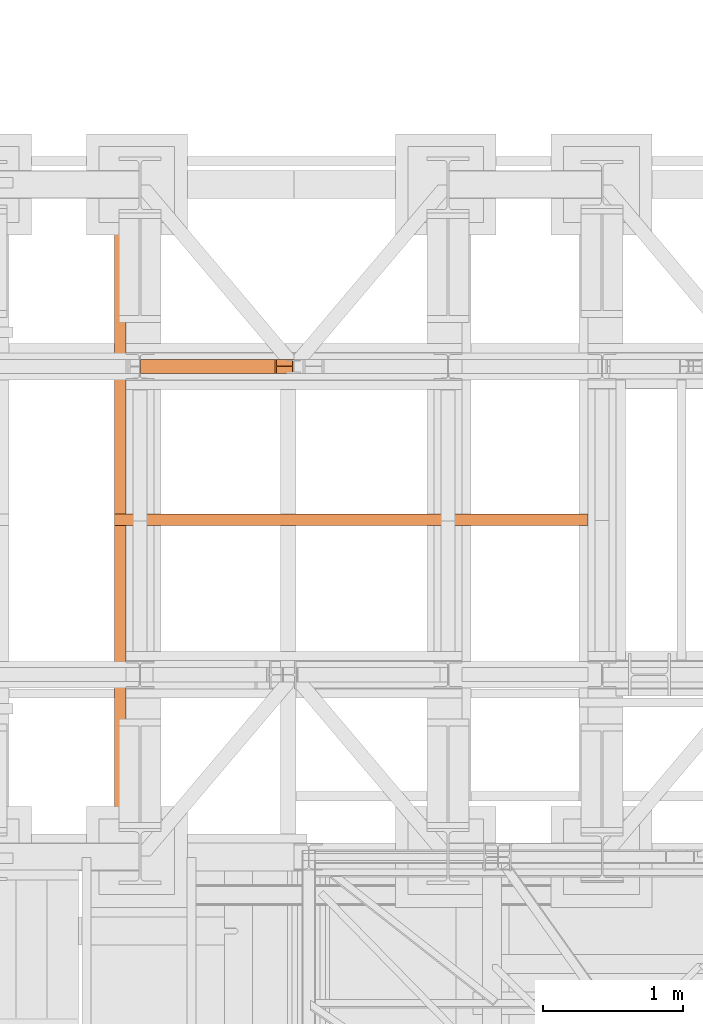
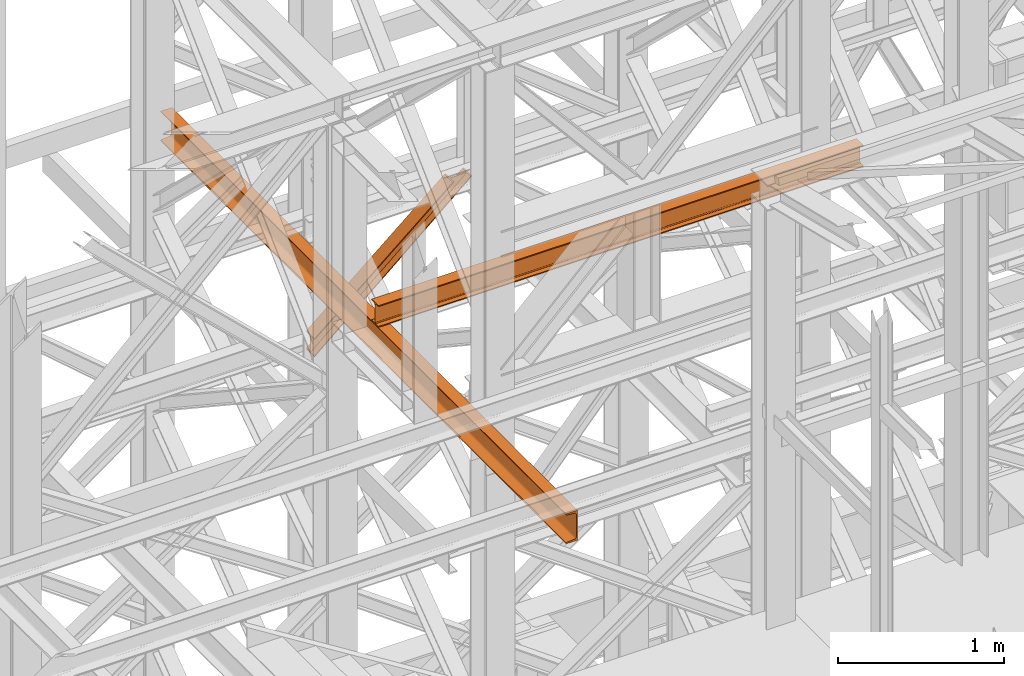
# One storey, part 117 of 208: 3 proxies.
"""IFC2X3 building model written with IfcOpenShell, lengths in millimetres."""

from ifc_helpers import new_model, entity, si_unit, converted_unit, frame, origin, origin_with_axes, place, context, subcontext, project, spatial, faceted_brep, element, save


model = new_model("IFC2X3")

# Units and contexts
model_context = context("Model", 3, precision=1e-05, world=origin())
plan_context = context("Plan", 3, precision=1e-05, world=origin())
body_context = subcontext(model_context, "Body", "Model", "MODEL_VIEW")
ifc_project = project(units=[si_unit("LENGTHUNIT", "METRE", prefix="MILLI"), converted_unit("PLANEANGLEUNIT", "DEGREE", entity("IfcPlaneAngleMeasure", 0.0174532925199433), si_unit("PLANEANGLEUNIT", "RADIAN"), dimensions=[0, 0, 0, 0, 0, 0, 0]), si_unit("AREAUNIT", "SQUARE_METRE"), si_unit("VOLUMEUNIT", "CUBIC_METRE")], contexts=[model_context, plan_context])

# Building, storey
building_placement = place(None, origin())
building = spatial("IfcBuilding", under=ifc_project, at=building_placement, CompositionType="COMPLEX")
storey_placement = place(building_placement, origin_with_axes())
storey = spatial("IfcBuildingStorey", under=building, at=storey_placement, Name="Geschoss", CompositionType="ELEMENT")

# Proxies
proxy_1_placement = place(storey_placement, frame((-4.245031471320317, -13810.57439404318, 8758.997679309408), z_axis=(0.0, 0.0, 1.0), x_axis=(1.0, 0.0, 0.0)))
element("IfcBuildingElementProxy", 1, at=proxy_1_placement, inside=storey, context=body_context, shape_type="Brep", body=[
    faceted_brep([(0.009999999999990905, 0.01000000000021828, 127.7973220590939), (0.009999999999990905, 0.01000000000021828, 136.1625718196283), (962.65812429219, 0.01000000000021828, 951.1180339129332), (973.8667654682147, 0.01000000000021828, 951.1180339129351), (0.009999999999990905, 0.01000000000021828, 136.1625718196283), (0.009999999999990905, 100.0100000000002, 136.1625718196283), (962.6581242921882, 100.0100000000002, 951.1180339129332), (962.65812429219, 0.01000000000021828, 951.1180339129332), (0.009999999999990905, 100.0100000000002, 136.1625718196283), (0.009999999999990905, 100.0100000000002, 127.7973220590939), (973.8667654682147, 100.0100000000002, 951.1180339129351), (962.6581242921882, 100.0100000000002, 951.1180339129332), (0.009999999999990905, 100.0100000000002, 127.7973220590939), (0.009999999999990905, 52.51000000000022, 127.7973220590939), (973.8667654682138, 52.51000000000022, 951.1180339129332), (973.8667654682147, 100.0100000000002, 951.1180339129351), (0.009999999999990905, 52.51000000000022, 127.7973220590939), (0.009999999999990905, 52.51000000000022, 8.373726266809172), (1088.159432762697, 52.51000000000022, 951.1180339129351), (973.8667654682138, 52.51000000000022, 951.1180339129332), (0.009999999999990905, 52.51000000000022, 8.373726266809172), (0.009999999999990905, 100.0100000000002, 8.37372626681281), (1088.159432762697, 100.0100000000002, 951.1180339129351), (1088.159432762697, 52.51000000000022, 951.1180339129351), (0.009999999999990905, 100.0100000000002, 8.37372626681281), (0.009999999999990905, 100.0100000000002, 0.01000000000203727), (1099.291108934561, 100.0100000000002, 951.1180339129369), (1088.159432762697, 100.0100000000002, 951.1180339129351), (0.009999999999990905, 100.0100000000002, 0.01000000000203727), (0.009999999999990905, 0.01000000000021828, 0.01000000000021828), (1099.291108934561, 0.01000000000021828, 951.1180339129369), (1099.291108934561, 100.0100000000002, 951.1180339129369), (0.009999999999990905, 0.01000000000021828, 0.01000000000021828), (0.009999999999990905, 0.01000000000021828, 8.37372626681281), (1088.159432762697, 0.01000000000021828, 951.1180339129351), (1099.291108934561, 0.01000000000021828, 951.1180339129369), (0.009999999999990905, 0.01000000000021828, 8.37372626681281), (0.009999999999990905, 47.51000000000022, 8.373726266816448), (1088.159432762696, 47.51000000000022, 951.1180339129351), (1088.159432762697, 0.01000000000021828, 951.1180339129351), (0.009999999999990905, 47.51000000000022, 8.373726266816448), (0.009999999999990905, 47.51000000000022, 127.7973220590939), (973.8667654682147, 47.51000000000022, 951.1180339129351), (1088.159432762696, 47.51000000000022, 951.1180339129351), (0.009999999999990905, 47.51000000000022, 127.7973220590939), (0.009999999999990905, 0.01000000000021828, 127.7973220590939), (973.8667654682147, 0.01000000000021828, 951.1180339129351), (973.8667654682147, 47.51000000000022, 951.1180339129351), (973.8667654682147, 0.01000000000021828, 951.1180339129351), (962.65812429219, 0.01000000000021828, 951.1180339129332), (962.6581242921882, 100.0100000000002, 951.1180339129332), (973.8667654682147, 100.0100000000002, 951.1180339129351), (973.8667654682138, 52.51000000000022, 951.1180339129332), (1088.159432762697, 52.51000000000022, 951.1180339129351), (1088.159432762697, 100.0100000000002, 951.1180339129351), (1099.291108934561, 100.0100000000002, 951.1180339129369), (1099.291108934561, 0.01000000000021828, 951.1180339129369), (1088.159432762697, 0.01000000000021828, 951.1180339129351), (1088.159432762696, 47.51000000000022, 951.1180339129351), (973.8667654682147, 47.51000000000022, 951.1180339129351), (0.009999999999990905, 0.01000000000021828, 136.1625718196283), (0.009999999999990905, 0.01000000000021828, 127.7973220590939), (0.009999999999990905, 47.51000000000022, 127.7973220590939), (0.009999999999990905, 47.51000000000022, 8.373726266816448), (0.009999999999990905, 0.01000000000021828, 8.37372626681281), (0.009999999999990905, 0.01000000000021828, 0.01000000000021828), (0.009999999999990905, 100.0100000000002, 0.01000000000203727), (0.009999999999990905, 100.0100000000002, 8.37372626681281), (0.009999999999990905, 52.51000000000022, 8.373726266809172), (0.009999999999990905, 52.51000000000022, 127.7973220590939), (0.009999999999990905, 100.0100000000002, 127.7973220590939), (0.009999999999990905, 100.0100000000002, 136.1625718196283)], [[[0, 1, 2, 3]], [[4, 5, 6, 7]], [[8, 9, 10, 11]], [[12, 13, 14, 15]], [[16, 17, 18, 19]], [[20, 21, 22, 23]], [[24, 25, 26, 27]], [[28, 29, 30, 31]], [[32, 33, 34, 35]], [[36, 37, 38, 39]], [[40, 41, 42, 43]], [[44, 45, 46, 47]], [[48, 49, 50, 51, 52, 53, 54, 55, 56, 57, 58, 59]], [[60, 61, 62, 63, 64, 65, 66, 67, 68, 69, 70, 71]]], orient=[[False], [False], [False], [False], [False], [False], [False], [False], [False], [False], [False], [False], [False], [False]]),
])
proxy_2_placement = place(storey_placement, frame((-186.6673710449029, -17162.574391808, 9479.99), z_axis=(0.0, 0.0, 1.0), x_axis=(1.0, 0.0, 0.0)))
element("IfcBuildingElementProxy", 2, at=proxy_2_placement, inside=storey, context=body_context, shape_type="Brep", body=[
    faceted_brep([(0.3882536331564097, 4894.878894768568, 220.0100000000002), (0.009999999999990905, 0.00999999999839929, 220.0100000000002), (0.009999999999990905, 0.00999999999839929, 216.3507668260718), (0.3882536331564097, 4894.878894768568, 216.3507668260718), (0.3882536331564097, 4894.878894768568, 216.3507668260718), (0.009999999999990905, 0.00999999999839929, 216.3507668260718), (0.2968705002965635, 0.00999999999839929, 214.4411131085253), (0.6751241334529823, 4894.878894768568, 214.4411131085253), (0.6751241334529823, 4894.878894768568, 214.4411131085253), (0.2968705002965635, 0.00999999999839929, 214.4411131085253), (1.132098207624722, 0.00999999999839929, 212.7000047486563), (1.510351840781141, 4894.878894768568, 212.7000047486563), (1.510351840781141, 4894.878894768568, 212.7000047486563), (1.132098207624722, 0.00999999999839929, 212.7000047486563), (2.442002609082692, 0.00999999999839929, 211.281122986331), (2.820256242239111, 4894.878894768568, 211.281122986331), (2.820256242239111, 4894.878894768568, 211.281122986331), (2.442002609082692, 0.00999999999839929, 211.281122986331), (4.110960604608181, 0.00999999999839929, 210.3097101734329), (4.489214237766419, 4894.878894768568, 210.3097101734329), (4.489214237766419, 4894.878894768568, 210.3097101734329), (4.110960604608181, 0.00999999999839929, 210.3097101734329), (5.991656055160775, 0.00999999999839929, 209.8714675155879), (6.369909688319012, 4894.878894768568, 209.8714675155879), (6.369909688319012, 4894.878894768568, 209.8714675155879), (5.991656055160775, 0.00999999999839929, 209.8714675155879), (59.50681527853499, 0.00999999999839929, 205.5902547777168), (59.88506891169322, 4894.878894768568, 205.5902547777168), (59.88506891169322, 4894.878894768568, 205.5902547777168), (59.50681527853499, 0.00999999999839929, 205.5902547777168), (63.12353729883012, 0.00999999999839929, 204.7474804357062), (63.50179093198472, 4894.878894768568, 204.7474804357062), (63.50179093198472, 4894.878894768568, 204.7474804357062), (63.12353729883012, 0.00999999999839929, 204.7474804357062), (66.33307190561004, 0.00999999999839929, 202.8793788724415), (66.71132553876828, 4894.878894768568, 202.8793788724415), (66.71132553876828, 4894.878894768568, 202.8793788724415), (66.33307190561004, 0.00999999999839929, 202.8793788724415), (68.85211883149145, 0.00999999999839929, 200.1507600987407), (69.23037246464787, 4894.878894768568, 200.1507600987407), (69.23037246464787, 4894.878894768568, 200.1507600987407), (68.85211883149145, 0.00999999999839929, 200.1507600987407), (70.45832596096966, 0.00999999999839929, 196.8024747913005), (70.83657959412608, 4894.878894768568, 196.8024747913005), (70.83657959412608, 4894.878894768568, 196.8024747913005), (70.45832596096966, 0.00999999999839929, 196.8024747913005), (71.00999999999999, 0.00999999999839929, 193.1300637960158), (71.38825363315641, 4894.878894768568, 193.1300637960158), (71.38825363315641, 4894.878894768568, 193.1300637960158), (71.00999999999999, 0.00999999999839929, 193.1300637960158), (71.00999999999999, 0.00999999999839929, 26.88993620398469), (71.38825363315641, 4894.878894768568, 26.88993620398469), (71.38825363315641, 4894.878894768568, 26.88993620398469), (71.00999999999999, 0.00999999999839929, 26.88993620398469), (70.45832596096966, 0.00999999999839929, 23.21752520870177), (70.83657959412608, 4894.878894768568, 23.21752520870177), (70.83657959412608, 4894.878894768568, 23.21752520870177), (70.45832596096966, 0.00999999999839929, 23.21752520870177), (68.85211883149145, 0.00999999999839929, 19.86923990125979), (69.23037246464787, 4894.878894768568, 19.86923990125979), (69.23037246464787, 4894.878894768568, 19.86923990125979), (68.85211883149145, 0.00999999999839929, 19.86923990125979), (66.33307190561186, 0.00999999999839929, 17.14062112755892), (66.71132553876828, 4894.878894768568, 17.14062112755892), (66.71132553876828, 4894.878894768568, 17.14062112755892), (66.33307190561186, 0.00999999999839929, 17.14062112755892), (63.12353729883012, 0.00999999999839929, 15.27251956429427), (63.50179093198472, 4894.878894768568, 15.27251956429427), (63.50179093198472, 4894.878894768568, 15.27251956429427), (63.12353729883012, 0.00999999999839929, 15.27251956429427), (59.50681527853681, 0.00999999999839929, 14.4297452222836), (59.88506891169322, 4894.878894768568, 14.4297452222836), (59.88506891169322, 4894.878894768568, 14.4297452222836), (59.50681527853681, 0.00999999999839929, 14.4297452222836), (5.991656055160775, 0.00999999999839929, 10.1485324844125), (6.369909688319012, 4894.878894768568, 10.1485324844125), (6.369909688319012, 4894.878894768568, 10.1485324844125), (5.991656055160775, 0.00999999999839929, 10.1485324844125), (4.110960604608181, 0.00999999999839929, 9.710289826567532), (4.489214237766419, 4894.878894768568, 9.710289826567532), (4.489214237766419, 4894.878894768568, 9.710289826567532), (4.110960604608181, 0.00999999999839929, 9.710289826567532), (2.442002609082692, 0.00999999999839929, 8.73887701366948), (2.820256242239111, 4894.878894768568, 8.73887701366948), (2.820256242239111, 4894.878894768568, 8.73887701366948), (2.442002609082692, 0.00999999999839929, 8.73887701366948), (1.132098207624722, 0.00999999999839929, 7.319995251345972), (1.510351840781141, 4894.878894768568, 7.319995251345972), (1.510351840781141, 4894.878894768568, 7.319995251345972), (1.132098207624722, 0.00999999999839929, 7.319995251345972), (0.2968705002965635, 0.00999999999839929, 5.578886891475122), (0.6751241334529823, 4894.878894768568, 5.578886891475122), (0.6751241334529823, 4894.878894768568, 5.578886891475122), (0.2968705002965635, 0.00999999999839929, 5.578886891475122), (0.009999999999990905, 0.00999999999839929, 3.66923317392866), (0.3882536331564097, 4894.878894768568, 3.66923317392866), (0.3882536331564097, 4894.878894768568, 3.66923317392866), (0.009999999999990905, 0.00999999999839929, 3.66923317392866), (0.009999999999990905, 0.00999999999839929, 0.01000000000021828), (0.3882536331564097, 4894.878894768568, 0.01000000000021828), (0.3882536331564097, 4894.878894768568, 0.01000000000021828), (0.009999999999990905, 0.00999999999839929, 0.01000000000021828), (80.00999999999999, 0.00999999999839929, 0.01000000000021828), (80.38825363315641, 4894.878894768568, 0.01000000000021828), (80.38825363315641, 4894.878894768568, 0.01000000000021828), (80.00999999999999, 0.00999999999839929, 0.01000000000021828), (80.00999999999999, 0.00999999999839929, 220.0100000000002), (80.38825363315641, 4894.878894768568, 220.0100000000002), (80.38825363315641, 4894.878894768568, 220.0100000000002), (80.00999999999999, 0.00999999999839929, 220.0100000000002), (0.009999999999990905, 0.00999999999839929, 220.0100000000002), (0.3882536331564097, 4894.878894768568, 220.0100000000002), (0.3882536331564097, 4894.878894768568, 220.0100000000002), (0.3882536331564097, 4894.878894768568, 216.3507668260718), (0.6751241334529823, 4894.878894768568, 214.4411131085253), (1.510351840781141, 4894.878894768568, 212.7000047486563), (2.820256242239111, 4894.878894768568, 211.281122986331), (4.489214237766419, 4894.878894768568, 210.3097101734329), (6.369909688319012, 4894.878894768568, 209.8714675155879), (59.88506891169322, 4894.878894768568, 205.5902547777168), (63.50179093198472, 4894.878894768568, 204.7474804357062), (66.71132553876828, 4894.878894768568, 202.8793788724415), (69.23037246464787, 4894.878894768568, 200.1507600987407), (70.83657959412608, 4894.878894768568, 196.8024747913005), (71.38825363315641, 4894.878894768568, 193.1300637960158), (71.38825363315641, 4894.878894768568, 26.88993620398469), (70.83657959412608, 4894.878894768568, 23.21752520870177), (69.23037246464787, 4894.878894768568, 19.86923990125979), (66.71132553876828, 4894.878894768568, 17.14062112755892), (63.50179093198472, 4894.878894768568, 15.27251956429427), (59.88506891169322, 4894.878894768568, 14.4297452222836), (6.369909688319012, 4894.878894768568, 10.1485324844125), (4.489214237766419, 4894.878894768568, 9.710289826567532), (2.820256242239111, 4894.878894768568, 8.73887701366948), (1.510351840781141, 4894.878894768568, 7.319995251345972), (0.6751241334529823, 4894.878894768568, 5.578886891475122), (0.3882536331564097, 4894.878894768568, 3.66923317392866), (0.3882536331564097, 4894.878894768568, 0.01000000000021828), (80.38825363315641, 4894.878894768568, 0.01000000000021828), (80.38825363315641, 4894.878894768568, 220.0100000000002), (0.009999999999990905, 0.00999999999839929, 220.0100000000002), (80.00999999999999, 0.00999999999839929, 220.0100000000002), (80.00999999999999, 0.00999999999839929, 0.01000000000021828), (0.009999999999990905, 0.00999999999839929, 0.01000000000021828), (0.009999999999990905, 0.00999999999839929, 3.66923317392866), (0.2968705002965635, 0.00999999999839929, 5.578886891475122), (1.132098207624722, 0.00999999999839929, 7.319995251345972), (2.442002609082692, 0.00999999999839929, 8.73887701366948), (4.110960604608181, 0.00999999999839929, 9.710289826567532), (5.991656055160775, 0.00999999999839929, 10.1485324844125), (59.50681527853681, 0.00999999999839929, 14.4297452222836), (63.12353729883012, 0.00999999999839929, 15.27251956429427), (66.33307190561186, 0.00999999999839929, 17.14062112755892), (68.85211883149145, 0.00999999999839929, 19.86923990125979), (70.45832596096966, 0.00999999999839929, 23.21752520870177), (71.00999999999999, 0.00999999999839929, 26.88993620398469), (71.00999999999999, 0.00999999999839929, 193.1300637960158), (70.45832596096966, 0.00999999999839929, 196.8024747913005), (68.85211883149145, 0.00999999999839929, 200.1507600987407), (66.33307190561004, 0.00999999999839929, 202.8793788724415), (63.12353729883012, 0.00999999999839929, 204.7474804357062), (59.50681527853499, 0.00999999999839929, 205.5902547777168), (5.991656055160775, 0.00999999999839929, 209.8714675155879), (4.110960604608181, 0.00999999999839929, 210.3097101734329), (2.442002609082692, 0.00999999999839929, 211.281122986331), (1.132098207624722, 0.00999999999839929, 212.7000047486563), (0.2968705002965635, 0.00999999999839929, 214.4411131085253), (0.009999999999990905, 0.00999999999839929, 216.3507668260718)], [[[0, 1, 2, 3]], [[4, 5, 6, 7]], [[8, 9, 10, 11]], [[12, 13, 14, 15]], [[16, 17, 18, 19]], [[20, 21, 22, 23]], [[24, 25, 26, 27]], [[28, 29, 30, 31]], [[32, 33, 34, 35]], [[36, 37, 38, 39]], [[40, 41, 42, 43]], [[44, 45, 46, 47]], [[48, 49, 50, 51]], [[52, 53, 54, 55]], [[56, 57, 58, 59]], [[60, 61, 62, 63]], [[64, 65, 66, 67]], [[68, 69, 70, 71]], [[72, 73, 74, 75]], [[76, 77, 78, 79]], [[80, 81, 82, 83]], [[84, 85, 86, 87]], [[88, 89, 90, 91]], [[92, 93, 94, 95]], [[96, 97, 98, 99]], [[100, 101, 102, 103]], [[104, 105, 106, 107]], [[108, 109, 110, 111]], [[112, 113, 114, 115, 116, 117, 118, 119, 120, 121, 122, 123, 124, 125, 126, 127, 128, 129, 130, 131, 132, 133, 134, 135, 136, 137, 138, 139]], [[140, 141, 142, 143, 144, 145, 146, 147, 148, 149, 150, 151, 152, 153, 154, 155, 156, 157, 158, 159, 160, 161, 162, 163, 164, 165, 166, 167]]], orient=[[False], [False], [False], [False], [False], [False], [False], [False], [False], [False], [False], [False], [False], [False], [False], [False], [False], [False], [False], [False], [False], [False], [False], [False], [False], [False], [False], [False], [False], [False]]),
])
proxy_3_placement = place(storey_placement, frame((-186.492257332651, -14896.48556403224, 9699.99), z_axis=(0.0, 0.0, 1.0), x_axis=(1.0, 0.0, 0.0)))
element("IfcBuildingElementProxy", 3, at=proxy_3_placement, inside=storey, context=body_context, shape_type="Brep", body=[
    faceted_brep([(3379.757224371198, 0.01000000000021828, 160.0100000000002), (0.009999999999990905, 0.01616250976258016, 160.0100000000002), (0.009999999999990905, 82.01616250976258, 160.0100000000002), (3379.757224371198, 82.01000000000022, 160.0100000000002), (3379.757224371198, 82.01000000000022, 160.0100000000002), (0.009999999999990905, 82.01616250976258, 160.0100000000002), (0.009999999999990905, 82.01616250976258, 152.6099999046328), (3379.757224371198, 82.01000000000022, 152.6099999046328), (3379.757224371198, 82.01000000000022, 152.6099999046328), (0.009999999999990905, 82.01616250976258, 152.6099999046328), (0.009999999999990905, 52.51616250976258, 152.6099999046328), (3379.757224371198, 52.51000000000022, 152.6099999046328), (3379.757224371198, 52.51000000000022, 152.6099999046328), (0.009999999999990905, 52.51616250976258, 152.6099999046328), (0.009999999999990905, 50.18679891617103, 152.3033059671343), (3379.757224371198, 50.18063640640685, 152.3033059671343), (3379.757224371198, 50.18063640640685, 152.3033059671343), (0.009999999999990905, 50.18679891617103, 152.3033059671343), (0.009999999999990905, 48.01617563491527, 151.4042043652353), (3379.757224371198, 48.01001312515291, 151.4042043652353), (3379.757224371198, 48.01001312515291, 151.4042043652353), (0.009999999999990905, 48.01617563491527, 151.4042043652353), (0.009999999999990905, 46.1522014790844, 149.973960935311), (3379.757224371198, 46.14603896932022, 149.973960935311), (3379.757224371198, 46.14603896932022, 149.973960935311), (0.009999999999990905, 46.1522014790844, 149.973960935311), (0.009999999999990905, 44.72195804915828, 148.1099867794801), (3379.757224371198, 44.71579553939591, 148.1099867794801), (3379.757224371198, 44.71579553939591, 148.1099867794801), (0.009999999999990905, 44.72195804915828, 148.1099867794801), (0.009999999999990905, 43.82285644726107, 145.9393634982243), (3379.757224371198, 43.81669393749689, 145.9393634982243), (3379.757224371198, 43.81669393749689, 145.9393634982243), (0.009999999999990905, 43.82285644726107, 145.9393634982243), (0.009999999999990905, 43.51616250976258, 143.6099999046328), (3379.757224371198, 43.51000000000022, 143.6099999046328), (3379.757224371198, 43.51000000000022, 143.6099999046328), (0.009999999999990905, 43.51616250976258, 143.6099999046328), (0.009999999999990905, 43.51616250976258, 16.41000009536765), (3379.757224371198, 43.51000000000022, 16.41000009536765), (3379.757224371198, 43.51000000000022, 16.41000009536765), (0.009999999999990905, 43.51616250976258, 16.41000009536765), (0.009999999999990905, 43.82285644726107, 14.08063650177428), (3379.757224371198, 43.81669393749689, 14.08063650177428), (3379.757224371198, 43.81669393749689, 14.08063650177428), (0.009999999999990905, 43.82285644726107, 14.08063650177428), (0.009999999999990905, 44.72195804915828, 11.91001322052034), (3379.757224371198, 44.71579553939591, 11.91001322052034), (3379.757224371198, 44.71579553939591, 11.91001322052034), (0.009999999999990905, 44.72195804915828, 11.91001322052034), (0.009999999999990905, 46.1522014790844, 10.04603906468765), (3379.757224371198, 46.14603896932022, 10.04603906468765), (3379.757224371198, 46.14603896932022, 10.04603906468765), (0.009999999999990905, 46.1522014790844, 10.04603906468765), (0.009999999999990905, 48.01617563491527, 8.615795634763344), (3379.757224371198, 48.01001312515291, 8.615795634763344), (3379.757224371198, 48.01001312515291, 8.615795634763344), (0.009999999999990905, 48.01617563491527, 8.615795634763344), (0.009999999999990905, 50.18679891617103, 7.716694032864325), (3379.757224371198, 50.18063640640685, 7.716694032864325), (3379.757224371198, 50.18063640640685, 7.716694032864325), (0.009999999999990905, 50.18679891617103, 7.716694032864325), (0.009999999999990905, 52.51616250976258, 7.41000009536765), (3379.757224371198, 52.51000000000022, 7.41000009536765), (3379.757224371198, 52.51000000000022, 7.41000009536765), (0.009999999999990905, 52.51616250976258, 7.41000009536765), (0.009999999999990905, 82.01616250976258, 7.41000009536765), (3379.757224371198, 82.01000000000022, 7.41000009536765), (3379.757224371198, 82.01000000000022, 7.41000009536765), (0.009999999999990905, 82.01616250976258, 7.41000009536765), (0.009999999999990905, 82.01616250976258, 0.01000000000021828), (3379.757224371198, 82.01000000000022, 0.01000000000021828), (3379.757224371198, 82.01000000000022, 0.01000000000021828), (0.009999999999990905, 82.01616250976258, 0.01000000000021828), (0.009999999999990905, 0.01616250976258016, 0.01000000000021828), (3379.757224371198, 0.01000000000021828, 0.01000000000021828), (3379.757224371198, 0.01000000000021828, 0.01000000000021828), (0.009999999999990905, 0.01616250976258016, 0.01000000000021828), (0.009999999999990905, 0.01616250976258016, 7.41000009536765), (3379.757224371198, 0.01000000000021828, 7.41000009536765), (3379.757224371198, 0.01000000000021828, 7.41000009536765), (0.009999999999990905, 0.01616250976258016, 7.41000009536765), (0.009999999999990905, 29.51616250976258, 7.41000009536765), (3379.757224371198, 29.51000000000022, 7.41000009536765), (3379.757224371198, 29.51000000000022, 7.41000009536765), (0.009999999999990905, 29.51616250976258, 7.41000009536765), (0.009999999999990905, 31.84552610335413, 7.716694032864325), (3379.757224371198, 31.83936359359177, 7.716694032864325), (3379.757224371198, 31.83936359359177, 7.716694032864325), (0.009999999999990905, 31.84552610335413, 7.716694032864325), (0.009999999999990905, 34.01614938460989, 8.615795634763344), (3379.757224371198, 34.00998687484753, 8.615795634763344), (3379.757224371198, 34.00998687484753, 8.615795634763344), (0.009999999999990905, 34.01614938460989, 8.615795634763344), (0.009999999999990905, 35.88012354044076, 10.04603906468765), (3379.757224371198, 35.8739610306784, 10.04603906468765), (3379.757224371198, 35.8739610306784, 10.04603906468765), (0.009999999999990905, 35.88012354044076, 10.04603906468765), (0.009999999999990905, 37.31036697036689, 11.91001322052034), (3379.757224371198, 37.30420446060271, 11.91001322052034), (3379.757224371198, 37.30420446060271, 11.91001322052034), (0.009999999999990905, 37.31036697036689, 11.91001322052034), (0.009999999999990905, 38.20946857226409, 14.08063650177428), (3379.757224371198, 38.20330606250172, 14.08063650177428), (3379.757224371198, 38.20330606250172, 14.08063650177428), (0.009999999999990905, 38.20946857226409, 14.08063650177428), (0.009999999999990905, 38.51616250976258, 16.41000009536765), (3379.757224371198, 38.51000000000022, 16.41000009536765), (3379.757224371198, 38.51000000000022, 16.41000009536765), (0.009999999999990905, 38.51616250976258, 16.41000009536765), (0.009999999999990905, 38.51616250976258, 143.6099999046328), (3379.757224371198, 38.51000000000022, 143.6099999046328), (3379.757224371198, 38.51000000000022, 143.6099999046328), (0.009999999999990905, 38.51616250976258, 143.6099999046328), (0.009999999999990905, 38.20946857226409, 145.9393634982243), (3379.757224371198, 38.20330606250172, 145.9393634982243), (3379.757224371198, 38.20330606250172, 145.9393634982243), (0.009999999999990905, 38.20946857226409, 145.9393634982243), (0.009999999999990905, 37.31036697036689, 148.1099867794801), (3379.757224371198, 37.30420446060271, 148.1099867794801), (3379.757224371198, 37.30420446060271, 148.1099867794801), (0.009999999999990905, 37.31036697036689, 148.1099867794801), (0.009999999999990905, 35.88012354044076, 149.973960935311), (3379.757224371198, 35.8739610306784, 149.973960935311), (3379.757224371198, 35.8739610306784, 149.973960935311), (0.009999999999990905, 35.88012354044076, 149.973960935311), (0.009999999999990905, 34.01614938460989, 151.4042043652353), (3379.757224371198, 34.00998687484753, 151.4042043652353), (3379.757224371198, 34.00998687484753, 151.4042043652353), (0.009999999999990905, 34.01614938460989, 151.4042043652353), (0.009999999999990905, 31.84552610335413, 152.3033059671343), (3379.757224371198, 31.83936359359177, 152.3033059671343), (3379.757224371198, 31.83936359359177, 152.3033059671343), (0.009999999999990905, 31.84552610335413, 152.3033059671343), (0.009999999999990905, 29.51616250976258, 152.6099999046328), (3379.757224371198, 29.51000000000022, 152.6099999046328), (3379.757224371198, 29.51000000000022, 152.6099999046328), (0.009999999999990905, 29.51616250976258, 152.6099999046328), (0.009999999999990905, 0.01616250976258016, 152.6099999046328), (3379.757224371198, 0.01000000000021828, 152.6099999046328), (3379.757224371198, 0.01000000000021828, 152.6099999046328), (0.009999999999990905, 0.01616250976258016, 152.6099999046328), (0.009999999999990905, 0.01616250976258016, 160.0100000000002), (3379.757224371198, 0.01000000000021828, 160.0100000000002), (3379.757224371198, 0.01000000000021828, 160.0100000000002), (3379.757224371198, 82.01000000000022, 160.0100000000002), (3379.757224371198, 82.01000000000022, 152.6099999046328), (3379.757224371198, 52.51000000000022, 152.6099999046328), (3379.757224371198, 50.18063640640685, 152.3033059671343), (3379.757224371198, 48.01001312515291, 151.4042043652353), (3379.757224371198, 46.14603896932022, 149.973960935311), (3379.757224371198, 44.71579553939591, 148.1099867794801), (3379.757224371198, 43.81669393749689, 145.9393634982243), (3379.757224371198, 43.51000000000022, 143.6099999046328), (3379.757224371198, 43.51000000000022, 16.41000009536765), (3379.757224371198, 43.81669393749689, 14.08063650177428), (3379.757224371198, 44.71579553939591, 11.91001322052034), (3379.757224371198, 46.14603896932022, 10.04603906468765), (3379.757224371198, 48.01001312515291, 8.615795634763344), (3379.757224371198, 50.18063640640685, 7.716694032864325), (3379.757224371198, 52.51000000000022, 7.41000009536765), (3379.757224371198, 82.01000000000022, 7.41000009536765), (3379.757224371198, 82.01000000000022, 0.01000000000021828), (3379.757224371198, 0.01000000000021828, 0.01000000000021828), (3379.757224371198, 0.01000000000021828, 7.41000009536765), (3379.757224371198, 29.51000000000022, 7.41000009536765), (3379.757224371198, 31.83936359359177, 7.716694032864325), (3379.757224371198, 34.00998687484753, 8.615795634763344), (3379.757224371198, 35.8739610306784, 10.04603906468765), (3379.757224371198, 37.30420446060271, 11.91001322052034), (3379.757224371198, 38.20330606250172, 14.08063650177428), (3379.757224371198, 38.51000000000022, 16.41000009536765), (3379.757224371198, 38.51000000000022, 143.6099999046328), (3379.757224371198, 38.20330606250172, 145.9393634982243), (3379.757224371198, 37.30420446060271, 148.1099867794801), (3379.757224371198, 35.8739610306784, 149.973960935311), (3379.757224371198, 34.00998687484753, 151.4042043652353), (3379.757224371198, 31.83936359359177, 152.3033059671343), (3379.757224371198, 29.51000000000022, 152.6099999046328), (3379.757224371198, 0.01000000000021828, 152.6099999046328), (0.009999999999990905, 0.01616250976258016, 160.0100000000002), (0.009999999999990905, 0.01616250976258016, 152.6099999046328), (0.009999999999990905, 29.51616250976258, 152.6099999046328), (0.009999999999990905, 31.84552610335413, 152.3033059671343), (0.009999999999990905, 34.01614938460989, 151.4042043652353), (0.009999999999990905, 35.88012354044076, 149.973960935311), (0.009999999999990905, 37.31036697036689, 148.1099867794801), (0.009999999999990905, 38.20946857226409, 145.9393634982243), (0.009999999999990905, 38.51616250976258, 143.6099999046328), (0.009999999999990905, 38.51616250976258, 16.41000009536765), (0.009999999999990905, 38.20946857226409, 14.08063650177428), (0.009999999999990905, 37.31036697036689, 11.91001322052034), (0.009999999999990905, 35.88012354044076, 10.04603906468765), (0.009999999999990905, 34.01614938460989, 8.615795634763344), (0.009999999999990905, 31.84552610335413, 7.716694032864325), (0.009999999999990905, 29.51616250976258, 7.41000009536765), (0.009999999999990905, 0.01616250976258016, 7.41000009536765), (0.009999999999990905, 0.01616250976258016, 0.01000000000021828), (0.009999999999990905, 82.01616250976258, 0.01000000000021828), (0.009999999999990905, 82.01616250976258, 7.41000009536765), (0.009999999999990905, 52.51616250976258, 7.41000009536765), (0.009999999999990905, 50.18679891617103, 7.716694032864325), (0.009999999999990905, 48.01617563491527, 8.615795634763344), (0.009999999999990905, 46.1522014790844, 10.04603906468765), (0.009999999999990905, 44.72195804915828, 11.91001322052034), (0.009999999999990905, 43.82285644726107, 14.08063650177428), (0.009999999999990905, 43.51616250976258, 16.41000009536765), (0.009999999999990905, 43.51616250976258, 143.6099999046328), (0.009999999999990905, 43.82285644726107, 145.9393634982243), (0.009999999999990905, 44.72195804915828, 148.1099867794801), (0.009999999999990905, 46.1522014790844, 149.973960935311), (0.009999999999990905, 48.01617563491527, 151.4042043652353), (0.009999999999990905, 50.18679891617103, 152.3033059671343), (0.009999999999990905, 52.51616250976258, 152.6099999046328), (0.009999999999990905, 82.01616250976258, 152.6099999046328), (0.009999999999990905, 82.01616250976258, 160.0100000000002)], [[[0, 1, 2, 3]], [[4, 5, 6, 7]], [[8, 9, 10, 11]], [[12, 13, 14, 15]], [[16, 17, 18, 19]], [[20, 21, 22, 23]], [[24, 25, 26, 27]], [[28, 29, 30, 31]], [[32, 33, 34, 35]], [[36, 37, 38, 39]], [[40, 41, 42, 43]], [[44, 45, 46, 47]], [[48, 49, 50, 51]], [[52, 53, 54, 55]], [[56, 57, 58, 59]], [[60, 61, 62, 63]], [[64, 65, 66, 67]], [[68, 69, 70, 71]], [[72, 73, 74, 75]], [[76, 77, 78, 79]], [[80, 81, 82, 83]], [[84, 85, 86, 87]], [[88, 89, 90, 91]], [[92, 93, 94, 95]], [[96, 97, 98, 99]], [[100, 101, 102, 103]], [[104, 105, 106, 107]], [[108, 109, 110, 111]], [[112, 113, 114, 115]], [[116, 117, 118, 119]], [[120, 121, 122, 123]], [[124, 125, 126, 127]], [[128, 129, 130, 131]], [[132, 133, 134, 135]], [[136, 137, 138, 139]], [[140, 141, 142, 143]], [[144, 145, 146, 147, 148, 149, 150, 151, 152, 153, 154, 155, 156, 157, 158, 159, 160, 161, 162, 163, 164, 165, 166, 167, 168, 169, 170, 171, 172, 173, 174, 175, 176, 177, 178, 179]], [[180, 181, 182, 183, 184, 185, 186, 187, 188, 189, 190, 191, 192, 193, 194, 195, 196, 197, 198, 199, 200, 201, 202, 203, 204, 205, 206, 207, 208, 209, 210, 211, 212, 213, 214, 215]]], orient=[[False], [False], [False], [False], [False], [False], [False], [False], [False], [False], [False], [False], [False], [False], [False], [False], [False], [False], [False], [False], [False], [False], [False], [False], [False], [False], [False], [False], [False], [False], [False], [False], [False], [False], [False], [False], [False], [False]]),
])

save(model, "model.ifc")
